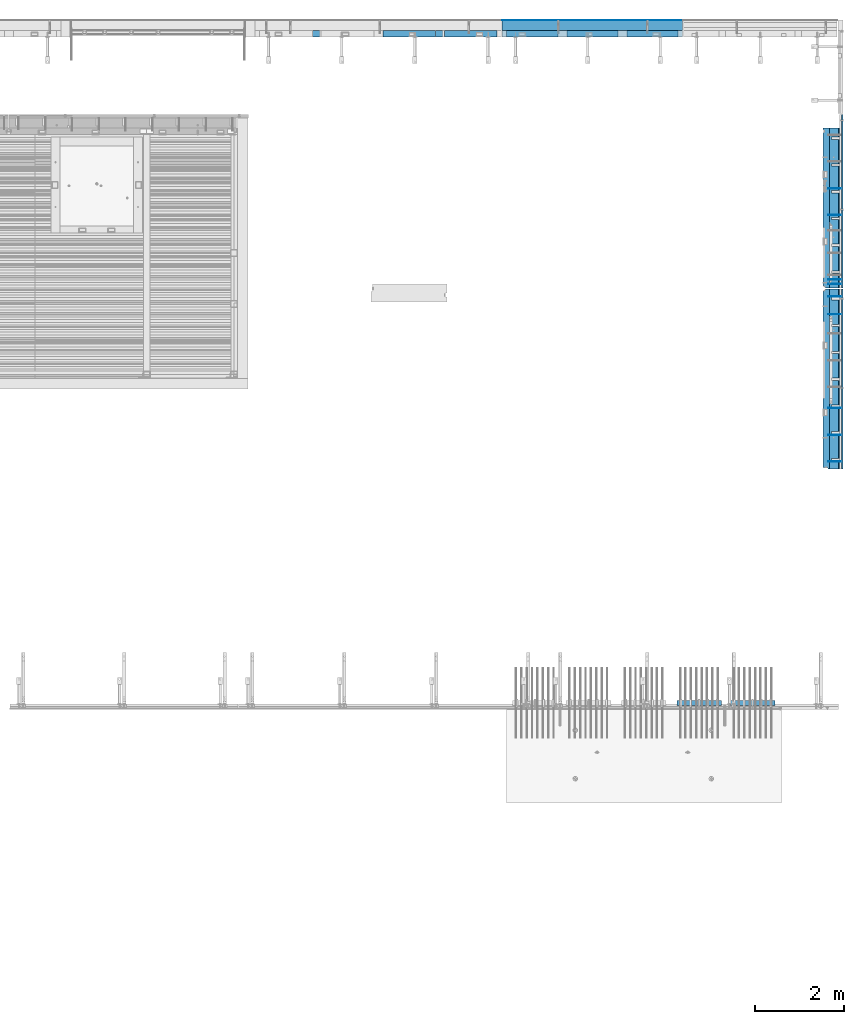
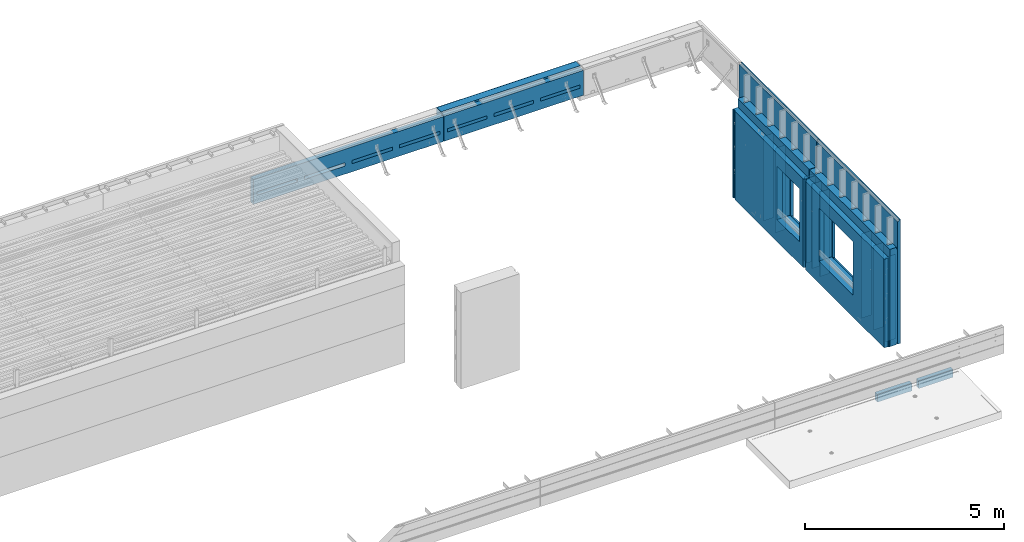
# One storey, part 81 of 153: 26 walls, 8 elements without a shape of their own.
"""IFC2X3 building model written with IfcOpenShell, lengths in millimetres."""

import ifcopenshell
import ifcopenshell.guid

model = None  # the IFC model being written
_history = None  # IfcOwnerHistory: only IFC2X3 demands one
_inside = {}  # id of a spatial element -> (the spatial element, [elements in it])
_under = {}  # id of a project, library or spatial element -> (it, [spatial elements below it])
_declared = {}  # id of a project -> (the project, [libraries it declares])
_typed = {}  # id of a type object -> (the type object, [elements of that type])
_made_of = {}  # id of a material, layer set ... -> (it, [elements and type objects made of it])


def new_model(schema):
    """Start an empty IFC model of exactly this schema.

    Asked for "IFC4X3", IfcOpenShell would pick the latest addendum, in which some entities
    have other attributes; the version numbers below select the first issue.
    IFC2X3 requires an IfcOwnerHistory on every rooted entity: one is made here for all.
    """
    global model, _history
    if schema == "IFC4X3":
        model = ifcopenshell.file(schema_version=(4, 3, 0, 0))
    else:
        model = ifcopenshell.file(schema=schema)
    _inside.clear()
    _under.clear()
    _declared.clear()
    _typed.clear()
    _made_of.clear()
    _history = None
    if model.schema == "IFC2X3":
        org = make("IfcOrganization", Name="unknown")
        user = make(
            "IfcPersonAndOrganization",
            ThePerson=make("IfcPerson", FamilyName="unknown"),
            TheOrganization=org,
        )
        app = make(
            "IfcApplication",
            ApplicationDeveloper=org,
            Version="unknown",
            ApplicationFullName="unknown",
            ApplicationIdentifier="unknown",
        )
        _history = make(
            "IfcOwnerHistory",
            OwningUser=user,
            OwningApplication=app,
            ChangeAction="ADDED",
            CreationDate=0,
        )
    return model


def make(cls, **values):
    """One entity of the class cls with the attributes given. An attribute that is None is left unset."""
    return model.create_entity(
        cls, **{name: value for name, value in values.items() if value is not None}
    )


def rooted(cls, **values):
    """An entity with a GlobalId (a new one), such as an element, a storey or a relation."""
    return make(cls, GlobalId=ifcopenshell.guid.new(), OwnerHistory=_history, **values)


def si_unit(unit_type, name, prefix=None):
    """IfcSIUnit, for example si_unit("LENGTHUNIT", "METRE", prefix="MILLI")."""
    return make("IfcSIUnit", UnitType=unit_type, Prefix=prefix, Name=name)


def assignment(units):
    """IfcUnitAssignment: the units of a project."""
    return None if units is None else make("IfcUnitAssignment", Units=units)


def point(xyz):
    """IfcCartesianPoint."""
    return None if xyz is None else make("IfcCartesianPoint", Coordinates=xyz)


def direction(xyz):
    """IfcDirection."""
    return None if xyz is None else make("IfcDirection", DirectionRatios=xyz)


def frame(location, z_axis=None, x_axis=None):
    """IfcAxis2Placement3D, a coordinate frame: its origin and axes. An axis left out is left unset."""
    return make(
        "IfcAxis2Placement3D",
        Location=point(location),
        Axis=direction(z_axis),
        RefDirection=direction(x_axis),
    )


def origin_with_axes():
    """The frame at (0, 0, 0) with the z axis (0, 0, 1) and the x axis (1, 0, 0) written out."""
    return frame((0.0, 0.0, 0.0), z_axis=(0.0, 0.0, 1.0), x_axis=(1.0, 0.0, 0.0))


def place(relative_to, where):
    """IfcLocalPlacement: puts the frame where relative to a parent placement (None: the world)."""
    return make(
        "IfcLocalPlacement", PlacementRelTo=relative_to, RelativePlacement=where
    )


def context(
    kind, dimensions, precision=None, world=None, true_north=None, identifier=None
):
    """IfcGeometricRepresentationContext, for example the 3D "Model" context."""
    return make(
        "IfcGeometricRepresentationContext",
        ContextIdentifier=identifier,
        ContextType=kind,
        CoordinateSpaceDimension=dimensions,
        Precision=precision,
        WorldCoordinateSystem=world,
        TrueNorth=true_north,
    )


def subcontext(parent, identifier, kind, view, scale=None):
    """IfcGeometricRepresentationSubContext, for example "Body" below "Model"."""
    return make(
        "IfcGeometricRepresentationSubContext",
        ContextIdentifier=identifier,
        ContextType=kind,
        ParentContext=parent,
        TargetScale=scale,
        TargetView=view,
    )


def project(units=None, contexts=None):
    """IfcProject with its units and contexts."""
    return rooted(
        "IfcProject",
        Name="project",
        RepresentationContexts=contexts,
        UnitsInContext=assignment(units),
    )


def spatial(cls, under=None, at=None, **own):
    """A site, building, storey or space (cls), placed at a placement, below another one or the project."""
    s = rooted(cls, ObjectPlacement=at, **own)
    if under is not None:
        _under.setdefault(under.id(), (under, []))[1].append(s)
    return s


def faces_of(points, faces, orient=None, outer=None):
    """IfcFace entities. A face is a list of loops; a loop is a list of indices into points, from 0.

    orient and outer hold one flag for each loop. By default every Orientation is true, the
    first loop of a face is its IfcFaceOuterBound and the others are IfcFaceBound.
    """
    made = []
    for i, loops in enumerate(faces):
        bounds = []
        for j, loop in enumerate(loops):
            is_outer = j == 0 if outer is None else outer[i][j]
            bounds.append(
                make(
                    "IfcFaceOuterBound" if is_outer else "IfcFaceBound",
                    Bound=make("IfcPolyLoop", Polygon=[points[k] for k in loop]),
                    Orientation=True if orient is None else orient[i][j],
                )
            )
        made.append(make("IfcFace", Bounds=bounds))
    return made


def faceted_brep(points, faces, orient=None, outer=None, voids=None):
    """IfcFacetedBrep: a solid bounded by flat faces; with voids (closed shells), ...WithVoids."""
    shared = [point(p) for p in points]
    hull = make("IfcClosedShell", CfsFaces=faces_of(shared, faces, orient, outer))
    if voids is None:
        return make("IfcFacetedBrep", Outer=hull)
    return make(
        "IfcFacetedBrepWithVoids",
        Outer=hull,
        Voids=[
            make(cls, CfsFaces=faces_of(shared, fs, o, b)) for cls, fs, o, b in voids
        ],
    )


def shape(context_of_items, identifier, shape_type, items):
    """IfcShapeRepresentation: the items that make up one representation, for example the "Body"."""
    return make(
        "IfcShapeRepresentation",
        ContextOfItems=context_of_items,
        RepresentationIdentifier=identifier,
        RepresentationType=shape_type,
        Items=items,
    )


def material(Name=None, Category=None):
    """IfcMaterial."""
    return make("IfcMaterial", Name=Name, Category=Category)


def made_of(thing, what):
    """Note that an element or type object is made of a material, layer set ...; save() writes the relation."""
    if what is not None:
        _made_of.setdefault(what.id(), (what, []))[1].append(thing)
    return thing


def type_object(cls, material=None, **own):
    """A type object (cls), such as IfcWallType, which elements share."""
    return made_of(rooted(cls, **own), material)


def element(
    cls,
    number,
    at=None,
    inside=None,
    cuts=None,
    type_object=None,
    material=None,
    context=None,
    identifier="Body",
    shape_type=None,
    held_by="IfcProductDefinitionShape",
    body=None,
    shapes=None,
    **own,
):
    """One element of the class cls, such as IfcWall. Its Tag is "e" and its number.

    at: its placement. inside: the storey or other place that contains it. cuts: it is an
    opening in that element (IfcRelVoidsElement). A single representation is given by context,
    identifier, shape_type and body (its items); several are given by shapes. held_by: the class
    of the entity that holds the representations. save() writes the other relations.
    """
    e = rooted(cls, Tag="e%d" % number, ObjectPlacement=at, **own)
    if body is not None:
        shapes = [shape(context, identifier, shape_type, body)]
    if shapes is not None:
        e.Representation = make(held_by, Representations=shapes)
    if inside is not None:
        _inside.setdefault(inside.id(), (inside, []))[1].append(e)
    if cuts is not None:
        rooted(
            "IfcRelVoidsElement", RelatingBuildingElement=cuts, RelatedOpeningElement=e
        )
    if type_object is not None:
        _typed.setdefault(type_object.id(), (type_object, []))[1].append(e)
    return made_of(e, material)


def aggregate(whole, parts):
    """IfcRelAggregates: a whole, such as a stair, and the parts it consists of."""
    return rooted("IfcRelAggregates", RelatingObject=whole, RelatedObjects=parts)


def save(model, path):
    """Write the relations noted so far, then the file.

    IfcRelAggregates (storeys below a building ...), IfcRelContainedInSpatialStructure (elements
    in a storey), IfcRelDefinesByType, IfcRelAssociatesMaterial and IfcRelDeclares: one each for
    every whole, place, type object, material and project.
    """
    for whole, parts in _under.values():
        aggregate(whole, parts)
    for where, things in _inside.values():
        rooted(
            "IfcRelContainedInSpatialStructure",
            RelatedElements=things,
            RelatingStructure=where,
        )
    for kind, things in _typed.values():
        rooted("IfcRelDefinesByType", RelatedObjects=things, RelatingType=kind)
    for what, things in _made_of.values():
        rooted("IfcRelAssociatesMaterial", RelatedObjects=things, RelatingMaterial=what)
    for by, libraries in _declared.values():
        rooted("IfcRelDeclares", RelatingContext=by, RelatedDefinitions=libraries)
    model.write(path)


model = new_model("IFC2X3")

# Units and contexts
model_context = context("Model", 3, precision=1e-05, world=origin_with_axes())
body_context = subcontext(model_context, "Body", "Model", "MODEL_VIEW")
ifc_project = project(units=[si_unit("LENGTHUNIT", "METRE", prefix="MILLI"), si_unit("AREAUNIT", "SQUARE_METRE"), si_unit("VOLUMEUNIT", "CUBIC_METRE"), si_unit("MASSUNIT", "GRAM", prefix="KILO"), si_unit("TIMEUNIT", "SECOND"), si_unit("PLANEANGLEUNIT", "RADIAN"), si_unit("SOLIDANGLEUNIT", "STERADIAN"), si_unit("THERMODYNAMICTEMPERATUREUNIT", "DEGREE_CELSIUS"), si_unit("LUMINOUSINTENSITYUNIT", "LUMEN")], contexts=[model_context])

# Site, building, storey
site_placement = place(None, origin_with_axes())
site = spatial("IfcSite", under=ifc_project, at=site_placement, CompositionType="ELEMENT")
building_placement = place(site_placement, origin_with_axes())
building = spatial("IfcBuilding", under=site, at=building_placement, CompositionType="ELEMENT")
storey_placement = place(building_placement, origin_with_axes())
storey = spatial("IfcBuildingStorey", under=building, at=storey_placement, Name="8", CompositionType="ELEMENT", Elevation=0.0)

# Assembly, walls
assembly_1_placement = place(storey_placement, origin_with_axes())
assembly_1 = element("IfcElementAssembly", 1, at=assembly_1_placement, inside=storey, AssemblyPlace="NOTDEFINED", PredefinedType="REINFORCEMENT_UNIT")
ifc_material_1 = material(Name="Undefined")
wall_type_1 = type_object("IfcWallType", PredefinedType="NOTDEFINED")
wall_1_placement = place(assembly_1_placement, frame((35030.0, 13100.0002861023, 101115.0), z_axis=(0.0, 0.0, 1.0), x_axis=(1.0, 0.0, 0.0)))
wall_1 = element("IfcWall", 2, at=wall_1_placement, type_object=wall_type_1, material=ifc_material_1, Name="(PD)", context=body_context, shape_type="Brep", body=[
    faceted_brep([(0.0, 5.0, -1300.0), (0.0, 5.0, 1300.0), (280.0, 5.0, 1300.0), (280.0, 5.0, -1300.0), (0.0, -5.0, 1300.0), (280.0, -5.0, 1300.0), (0.0, -5.0, -1300.0), (280.0, -5.0, -1300.0)], [[[0, 1, 2, 3]], [[1, 4, 5, 2]], [[4, 6, 7, 5]], [[6, 0, 3, 7]], [[5, 7, 3, 2]], [[6, 4, 1, 0]]]),
])
wall_2_placement = place(assembly_1_placement, frame((35030.0, 13700.0002861023, 101115.0), z_axis=(0.0, 0.0, 1.0), x_axis=(1.0, 0.0, 0.0)))
wall_2 = element("IfcWall", 3, at=wall_2_placement, type_object=wall_type_1, material=ifc_material_1, Name="(PD)", context=body_context, shape_type="Brep", body=[
    faceted_brep([(0.0, 5.0, -1300.0), (0.0, 5.0, 1300.0), (280.0, 5.0, 1300.0), (280.0, 5.0, -1300.0), (0.0, -5.0, 1300.0), (280.0, -5.0, 1300.0), (0.0, -5.0, -1300.0), (280.0, -5.0, -1300.0)], [[[0, 1, 2, 3]], [[1, 4, 5, 2]], [[4, 6, 7, 5]], [[6, 0, 3, 7]], [[5, 7, 3, 2]], [[6, 4, 1, 0]]]),
])
wall_3_placement = place(assembly_1_placement, frame((35030.0, 16804.6502861023, 101115.0), z_axis=(0.0, 0.0, 1.0), x_axis=(1.0, 0.0, 0.0)))
wall_3 = element("IfcWall", 4, at=wall_3_placement, type_object=wall_type_1, material=ifc_material_1, Name="(PD)", context=body_context, shape_type="Brep", body=[
    faceted_brep([(0.0, 5.0, -1300.0), (0.0, 5.0, 1300.0), (280.0, 5.0, 1300.0), (280.0, 5.0, -1300.0), (0.0, -5.0, 1300.0), (280.0, -5.0, 1300.0), (0.0, -5.0, -1300.0), (280.0, -5.0, -1300.0)], [[[0, 1, 2, 3]], [[1, 4, 5, 2]], [[4, 6, 7, 5]], [[6, 0, 3, 7]], [[5, 7, 3, 2]], [[6, 4, 1, 0]]]),
])
wall_4_placement = place(assembly_1_placement, frame((35030.0, 16404.6502861023, 101115.0), z_axis=(0.0, 0.0, 1.0), x_axis=(1.0, 0.0, 0.0)))
wall_4 = element("IfcWall", 5, at=wall_4_placement, type_object=wall_type_1, material=ifc_material_1, Name="(PD)", context=body_context, shape_type="Brep", body=[
    faceted_brep([(0.0, 5.0, -1300.0), (0.0, 5.0, 1300.0), (280.0, 5.0, 1300.0), (280.0, 5.0, -1300.0), (0.0, -5.0, 1300.0), (280.0, -5.0, 1300.0), (0.0, -5.0, -1300.0), (280.0, -5.0, -1300.0)], [[[0, 1, 2, 3]], [[1, 4, 5, 2]], [[4, 6, 7, 5]], [[6, 0, 3, 7]], [[5, 7, 3, 2]], [[6, 4, 1, 0]]]),
])

assembly_2_placement = place(storey_placement, origin_with_axes())
assembly_2 = element("IfcElementAssembly", 6, at=assembly_2_placement, inside=storey, AssemblyPlace="NOTDEFINED", PredefinedType="REINFORCEMENT_UNIT")
wall_5_placement = place(assembly_2_placement, frame((35030.0, 18625.0002441406, 101115.0), z_axis=(0.0, 0.0, 1.0), x_axis=(1.0, 0.0, 0.0)))
wall_5 = element("IfcWall", 7, at=wall_5_placement, type_object=wall_type_1, material=ifc_material_1, Name="(PD)", context=body_context, shape_type="Brep", body=[
    faceted_brep([(0.0, 5.0, -1300.0), (0.0, 5.0, 1300.0), (280.0, 5.0, 1300.0), (280.0, 5.0, -1300.0), (0.0, -5.0, 1300.0), (280.0, -5.0, 1300.0), (0.0, -5.0, -1300.0), (280.0, -5.0, -1300.0)], [[[0, 1, 2, 3]], [[1, 4, 5, 2]], [[4, 6, 7, 5]], [[6, 0, 3, 7]], [[5, 7, 3, 2]], [[6, 4, 1, 0]]]),
])
wall_6_placement = place(assembly_2_placement, frame((35030.0, 19225.0002441406, 101115.0), z_axis=(0.0, 0.0, 1.0), x_axis=(1.0, 0.0, 0.0)))
wall_6 = element("IfcWall", 8, at=wall_6_placement, type_object=wall_type_1, material=ifc_material_1, Name="(PD)", context=body_context, shape_type="Brep", body=[
    faceted_brep([(0.0, 5.0, -1300.0), (0.0, 5.0, 1300.0), (280.0, 5.0, 1300.0), (280.0, 5.0, -1300.0), (0.0, -5.0, 1300.0), (280.0, -5.0, 1300.0), (0.0, -5.0, -1300.0), (280.0, -5.0, -1300.0)], [[[0, 1, 2, 3]], [[1, 4, 5, 2]], [[4, 6, 7, 5]], [[6, 0, 3, 7]], [[5, 7, 3, 2]], [[6, 4, 1, 0]]]),
])
wall_7_placement = place(assembly_2_placement, frame((35030.0, 17180.0002441406, 101115.0), z_axis=(0.0, 0.0, 1.0), x_axis=(1.0, 0.0, 0.0)))
wall_7 = element("IfcWall", 9, at=wall_7_placement, type_object=wall_type_1, material=ifc_material_1, Name="(PD)", context=body_context, shape_type="Brep", body=[
    faceted_brep([(0.0, 5.0, -1300.0), (0.0, 5.0, 1300.0), (280.0, 5.0, 1300.0), (280.0, 5.0, -1300.0), (0.0, -5.0, 1300.0), (280.0, -5.0, 1300.0), (0.0, -5.0, -1300.0), (280.0, -5.0, -1300.0)], [[[0, 1, 2, 3]], [[1, 4, 5, 2]], [[4, 6, 7, 5]], [[6, 0, 3, 7]], [[5, 7, 3, 2]], [[6, 4, 1, 0]]]),
])
wall_8_placement = place(assembly_2_placement, frame((35030.0, 17080.0002441406, 101115.0), z_axis=(0.0, 0.0, 1.0), x_axis=(1.0, 0.0, 0.0)))
wall_8 = element("IfcWall", 10, at=wall_8_placement, type_object=wall_type_1, material=ifc_material_1, Name="(PD)", context=body_context, shape_type="Brep", body=[
    faceted_brep([(0.0, 5.0, -1300.0), (0.0, 5.0, 1300.0), (280.0, 5.0, 1300.0), (280.0, 5.0, -1300.0), (0.0, -5.0, 1300.0), (280.0, -5.0, 1300.0), (0.0, -5.0, -1300.0), (280.0, -5.0, -1300.0)], [[[0, 1, 2, 3]], [[1, 4, 5, 2]], [[4, 6, 7, 5]], [[6, 0, 3, 7]], [[5, 7, 3, 2]], [[6, 4, 1, 0]]]),
])

# Wall
wall_9_placement = place(assembly_1_placement, frame((35030.0, 14300.0002861023, 101115.0), z_axis=(0.0, 0.0, 1.0), x_axis=(1.0, 0.0, 0.0)))
wall_9 = element("IfcWall", 11, at=wall_9_placement, type_object=wall_type_1, material=ifc_material_1, Name="(PD)", context=body_context, shape_type="Brep", body=[
    faceted_brep([(0.0, 5.0, -1300.0), (0.0, 5.0, 1300.0), (280.0, 5.0, 1300.0), (280.0, 5.0, -1300.0), (0.0, -5.0, 1300.0), (280.0, -5.0, 1300.0), (0.0, -5.0, -1300.0), (280.0, -5.0, -1300.0)], [[[0, 1, 2, 3]], [[1, 4, 5, 2]], [[4, 6, 7, 5]], [[6, 0, 3, 7]], [[5, 7, 3, 2]], [[6, 4, 1, 0]]]),
])

# Assemblies, walls
assembly_3_placement = place(storey_placement, origin_with_axes())
assembly_3 = element("IfcElementAssembly", 12, at=assembly_3_placement, inside=storey, AssemblyPlace="NOTDEFINED", PredefinedType="REINFORCEMENT_UNIT")
assembly_4_placement = place(assembly_3_placement, origin_with_axes())
assembly_4 = element("IfcElementAssembly", 13, at=assembly_4_placement, Name="Steel Assembly", AssemblyPlace="NOTDEFINED", PredefinedType="NOTDEFINED")
ifc_material_2 = material()
wall_type_2 = type_object("IfcWallType", PredefinedType="NOTDEFINED")
wall_10_placement = place(assembly_4_placement, frame((27719.9999060453, 22880.0000027105, 103162.5), z_axis=(0.0, 0.0, 1.0), x_axis=(1.0, 0.0, 0.0)))
wall_10 = element("IfcWall", 14, at=wall_10_placement, type_object=wall_type_2, material=ifc_material_2, context=body_context, shape_type="Brep", body=[
    faceted_brep([(0.0, 110.0, -407.5), (0.0, 110.0, 407.5), (4044.9964105508, 110.0, 407.5), (4044.9964105508, 110.0, -407.5), (0.0, -110.0, 407.5), (4044.9964105508, -109.999999999996, 407.5), (0.0, -110.0, -407.5), (4044.9964105508, -109.999999999996, -407.5)], [[[0, 1, 2, 3]], [[1, 4, 5, 2]], [[4, 6, 7, 5]], [[6, 0, 3, 7]], [[5, 7, 3, 2]], [[6, 4, 1, 0]]]),
])
aggregate(assembly_4, [wall_10])
ifc_material_3 = material()
wall_type_3 = type_object("IfcWallType", PredefinedType="NOTDEFINED")
wall_11_placement = place(assembly_3_placement, frame((27719.9998642852, 22995.0000027105, 103162.5), z_axis=(0.0, 0.0, 1.0), x_axis=(1.0, 0.0, 0.0)))
wall_11 = element("IfcWall", 15, at=wall_11_placement, type_object=wall_type_3, material=ifc_material_3, context=body_context, shape_type="Brep", body=[
    faceted_brep([(0.0, 5.0, -407.5), (0.0, 5.0, 407.5), (4044.99641541972, 4.99999999999636, 407.5), (4044.99641541972, 4.99999999999636, -407.5), (0.0, -5.0, 407.5), (4044.99641541972, -5.00000000000364, 407.5), (0.0, -5.0, -407.5), (4044.99641541972, -5.00000000000364, -407.5)], [[[0, 1, 2, 3]], [[1, 4, 5, 2]], [[4, 6, 7, 5]], [[6, 0, 3, 7]], [[5, 7, 3, 2]], [[6, 4, 1, 0]]]),
])
ifc_material_4 = material(Name="EPS")
wall_type_4 = type_object("IfcWallType", PredefinedType="NOTDEFINED")
wall_12_placement = place(assembly_3_placement, frame((30520.0, 22695.0, 103055.0), z_axis=(0.0, 1.0, 0.0), x_axis=(1.0, 0.0, 0.0)))
wall_12 = element("IfcWall", 16, at=wall_12_placement, type_object=wall_type_4, material=ifc_material_4, context=body_context, shape_type="Brep", body=[
    faceted_brep([(0.0, 50.0, -75.0), (0.0, 50.0, 75.0), (1145.0, 50.0, 75.0), (1145.0, 50.0, -75.0), (0.0, -50.0, 75.0), (1145.0, -50.0, 75.0), (0.0, -50.0, -75.0), (1145.0, -50.0, -75.0)], [[[0, 1, 2, 3]], [[1, 4, 5, 2]], [[4, 6, 7, 5]], [[6, 0, 3, 7]], [[5, 7, 3, 2]], [[6, 4, 1, 0]]]),
])
wall_13_placement = place(assembly_3_placement, frame((29170.0, 22695.0, 103055.0), z_axis=(0.0, 1.0, 0.0), x_axis=(1.0, 0.0, 0.0)))
wall_13 = element("IfcWall", 17, at=wall_13_placement, type_object=wall_type_4, material=ifc_material_4, context=body_context, shape_type="Brep", body=[
    faceted_brep([(0.0, 50.0, -75.0), (0.0, 50.0, 75.0), (1150.0, 50.0, 75.0), (1150.0, 50.0, -75.0), (0.0, -50.0, 75.0), (1150.0, -50.0, 75.0), (0.0, -50.0, -75.0), (1150.0, -50.0, -75.0)], [[[0, 1, 2, 3]], [[1, 4, 5, 2]], [[4, 6, 7, 5]], [[6, 0, 3, 7]], [[5, 7, 3, 2]], [[6, 4, 1, 0]]]),
])
wall_14_placement = place(assembly_3_placement, frame((27820.0, 22695.0, 103055.0), z_axis=(0.0, 1.0, 0.0), x_axis=(1.0, 0.0, 0.0)))
wall_14 = element("IfcWall", 18, at=wall_14_placement, type_object=wall_type_4, material=ifc_material_4, context=body_context, shape_type="Brep", body=[
    faceted_brep([(0.0, 50.0, -75.0), (0.0, 50.0, 75.0), (1150.0, 50.0, 75.0), (1150.0, 50.0, -75.0), (0.0, -50.0, 75.0), (1150.0, -50.0, 75.0), (0.0, -50.0, -75.0), (1150.0, -50.0, -75.0)], [[[0, 1, 2, 3]], [[1, 4, 5, 2]], [[4, 6, 7, 5]], [[6, 0, 3, 7]], [[5, 7, 3, 2]], [[6, 4, 1, 0]]]),
])

# Assembly, walls
assembly_5_placement = place(storey_placement, origin_with_axes())
assembly_5 = element("IfcElementAssembly", 19, at=assembly_5_placement, inside=storey, AssemblyPlace="NOTDEFINED", PredefinedType="REINFORCEMENT_UNIT")
wall_15_placement = place(assembly_5_placement, frame((26425.0, 22695.0, 103055.0), z_axis=(0.0, 1.0, 0.0), x_axis=(1.0, 0.0, 0.0)))
wall_15 = element("IfcWall", 20, at=wall_15_placement, type_object=wall_type_4, material=ifc_material_4, context=body_context, shape_type="Brep", body=[
    faceted_brep([(0.0, 50.0, -75.0), (0.0, 50.0, 75.0), (1180.0, 50.0, 75.0), (1180.0, 50.0, -75.0), (0.0, -50.0, 75.0), (1180.0, -50.0, 75.0), (0.0, -50.0, -75.0), (1180.0, -50.0, -75.0)], [[[0, 1, 2, 3]], [[1, 4, 5, 2]], [[4, 6, 7, 5]], [[6, 0, 3, 7]], [[5, 7, 3, 2]], [[6, 4, 1, 0]]]),
])
wall_16_placement = place(assembly_5_placement, frame((25045.0, 22695.0, 103055.0), z_axis=(0.0, 1.0, 0.0), x_axis=(1.0, 0.0, 0.0)))
wall_16 = element("IfcWall", 21, at=wall_16_placement, type_object=wall_type_4, material=ifc_material_4, context=body_context, shape_type="Brep", body=[
    faceted_brep([(0.0, 50.0, -75.0), (0.0, 50.0, 75.0), (1180.0, 50.0, 75.0), (1180.0, 50.0, -75.0), (0.0, -50.0, 75.0), (1180.0, -50.0, 75.0), (0.0, -50.0, -75.0), (1180.0, -50.0, -75.0)], [[[0, 1, 2, 3]], [[1, 4, 5, 2]], [[4, 6, 7, 5]], [[6, 0, 3, 7]], [[5, 7, 3, 2]], [[6, 4, 1, 0]]]),
])

# Assemblies, walls
assembly_6_placement = place(storey_placement, origin_with_axes())
assembly_6 = element("IfcElementAssembly", 22, at=assembly_6_placement, inside=storey, AssemblyPlace="NOTDEFINED", PredefinedType="REINFORCEMENT_UNIT")
assembly_7_placement = place(assembly_6_placement, origin_with_axes())
assembly_7 = element("IfcElementAssembly", 23, at=assembly_7_placement, Name="Steel Assembly", AssemblyPlace="NOTDEFINED", PredefinedType="NOTDEFINED")
ifc_material_5 = material()
wall_type_5 = type_object("IfcWallType", PredefinedType="NOTDEFINED")
wall_17_placement = place(assembly_7_placement, frame((32834.9998568133, 7690.00021946163, 102590.0), z_axis=(0.0, 0.0, 1.0), x_axis=(1.0, 0.0, 0.0)))
wall_17 = element("IfcWall", 24, at=wall_17_placement, type_object=wall_type_5, material=ifc_material_5, context=body_context, shape_type="Brep", body=[
    faceted_brep([(0.0, 60.0, -120.0), (0.0, 60.0, 120.0), (1000.0, 60.0, 120.0), (1000.0, 60.0, -120.0), (0.0, -60.0, 120.0), (1000.0, -60.0, 120.0), (0.0, -60.0, -120.0), (1000.0, -60.0, -120.0)], [[[0, 1, 2, 3]], [[1, 4, 5, 2]], [[4, 6, 7, 5]], [[6, 0, 3, 7]], [[5, 7, 3, 2]], [[6, 4, 1, 0]]]),
])
aggregate(assembly_7, [wall_17])
assembly_8_placement = place(assembly_6_placement, origin_with_axes())
assembly_8 = element("IfcElementAssembly", 25, at=assembly_8_placement, Name="Steel Assembly", AssemblyPlace="NOTDEFINED", PredefinedType="NOTDEFINED")
aggregate(assembly_6, [assembly_7, assembly_8])
wall_18_placement = place(assembly_8_placement, frame((31634.9998568133, 7690.00021946163, 102590.0), z_axis=(0.0, 0.0, 1.0), x_axis=(1.0, 0.0, 0.0)))
wall_18 = element("IfcWall", 26, at=wall_18_placement, type_object=wall_type_5, material=ifc_material_5, context=body_context, shape_type="Brep", body=[
    faceted_brep([(0.0, 60.0, -120.0), (0.0, 60.0, 120.0), (1000.0, 60.0, 120.0), (1000.0, 60.0, -120.0), (0.0, -60.0, 120.0), (1000.0, -60.0, 120.0), (0.0, -60.0, -120.0), (1000.0, -60.0, -120.0)], [[[0, 1, 2, 3]], [[1, 4, 5, 2]], [[4, 6, 7, 5]], [[6, 0, 3, 7]], [[5, 7, 3, 2]], [[6, 4, 1, 0]]]),
])
aggregate(assembly_8, [wall_18])

# Wall
ifc_material_6 = material(Name="COS5gt")
wall_type_6 = type_object("IfcWallType", PredefinedType="NOTDEFINED")
wall_19_placement = place(assembly_1_placement, frame((35170.0, 16980.0002861023, 101247.5), z_axis=(0.0, 0.0, 1.0), x_axis=(0.0, -1.0, 0.0)))
wall_19 = element("IfcWall", 27, at=wall_19_placement, type_object=wall_type_6, material=ifc_material_6, context=body_context, shape_type="Brep", body=[
    faceted_brep([(3855.00004196167, -65.0, 1492.5), (3855.00004196167, -65.0, 622.5), (3805.00004196167, -65.0, 622.5), (3805.00004196167, -65.0, 1492.5), (3855.00004196167, 110.0, 1442.5), (3855.00004196167, 110.0, 622.5), (3855.00004196167, 90.0, 1492.5), (3855.00004196167, 90.0, 1442.5), (3805.00004196167, 110.0, 622.5), (3805.00004196167, 110.0, 1442.5), (3805.00004196167, 90.0, 1442.5), (3805.00004196167, 90.0, 1492.5), (2655.00004196167, 110.0, 1442.5), (2655.00004196167, 90.0, 1442.5), (3205.00004196167, 90.0, 1442.5), (3205.00004196167, 110.0, 1442.5), (2055.00004196167, 110.0, 1442.5), (2055.00004196167, 90.0, 1442.5), (2605.00004196167, 90.0, 1442.5), (2605.00004196167, 110.0, 1442.5), (1455.00004196167, 110.0, 1442.5), (1455.00004196167, 90.0, 1442.5), (2005.00004196167, 90.0, 1442.5), (2005.00004196167, 110.0, 1442.5), (855.00004196167, 110.0, 1442.5), (855.00004196167, 90.0, 1442.5), (1405.00004196167, 90.0, 1442.5), (1405.00004196167, 110.0, 1442.5), (255.0, 110.0, 1442.5), (255.0, 90.0, 1442.5), (805.00004196167, 90.0, 1442.5), (805.00004196167, 110.0, 1442.5), (1409.0, 90.0, -1492.5), (1409.0, 90.0, -1442.5), (4045.0, 90.0, -1442.5), (4045.0, 90.0, -1492.5), (4045.0, -110.0, -1492.5), (5.0, -110.0, -1492.5), (5.0, 110.0, -1492.5), (1409.0, 110.0, -1492.5), (1409.0, 110.0, -1442.5), (4045.0, 110.0, -1442.5), (4045.0, 110.0, 1442.5), (4045.0, 90.0, 1442.5), (4045.0, 90.0, 1492.5), (4045.0, -110.0, 1492.5), (2454.99993815724, 110.0, -802.5), (2454.99993815724, 110.0, -807.5), (2460.94588410319, -110.0, -813.445945945947), (2460.94588410319, -110.0, 813.445945945947), (2454.99993815724, 110.0, 807.5), (2424.99993815724, 110.0, -807.5), (774.99993815724, 110.0, -807.5), (744.99993815724, 110.0, -807.5), (739.053992211293, -110.0, -813.445945945947), (744.99993815724, 110.0, -802.5), (744.99993815724, 110.0, 807.5), (739.053992211293, -110.0, 813.445945945947), (5.0, -110.0, 1492.5), (5.00004196166992, 110.0, 1442.5), (5.00004196166992, 90.0, 1442.5), (205.00004196167, 90.0, 1442.5), (205.00004196167, 110.0, 1442.5), (5.00004196166992, 90.0, 1492.5), (205.00004196167, 90.0, 1492.5), (205.00004196167, 110.0, 622.5), (205.00004196167, -65.0, 622.5), (255.00004196167, -65.0, 622.5), (255.00004196167, 110.0, 622.5), (205.00004196167, -65.0, 1492.5), (255.00004196167, -65.0, 1492.5), (255.0, 90.0, 1492.5), (805.00004196167, 90.0, 1492.5), (805.00004196167, 110.0, 817.5), (805.00004196167, -65.0, 817.5), (855.00004196167, -65.0, 817.5), (855.00004196167, 110.0, 817.5), (805.00004196167, -65.0, 1492.5), (855.00004196167, -65.0, 1492.5), (855.00004196167, 90.0, 1492.5), (1405.00004196167, 90.0, 1492.5), (1405.00004196167, 110.0, 817.5), (1405.00004196167, -65.0, 817.5), (1455.00004196167, -65.0, 817.5), (1455.00004196167, 110.0, 817.5), (1405.00004196167, -65.0, 1492.5), (1455.00004196167, -65.0, 1492.5), (1455.00004196167, 90.0, 1492.5), (2005.00004196167, 90.0, 1492.5), (2005.00004196167, 110.0, 817.5), (2005.00004196167, -65.0, 817.5), (2055.00004196167, -65.0, 817.5), (2055.00004196167, 110.0, 817.5), (2005.00004196167, -65.0, 1492.5), (2055.00004196167, -65.0, 1492.5), (2055.00004196167, 90.0, 1492.5), (2605.00004196167, 90.0, 1492.5), (2605.00004196167, 110.0, 622.5), (2605.00004196167, -65.0, 622.5), (2655.00004196167, -65.0, 622.5), (2655.00004196167, 110.0, 622.5), (2605.00004196167, -65.0, 1492.5), (2655.00004196167, -65.0, 1492.5), (2655.00004196167, 90.0, 1492.5), (3205.00004196167, 90.0, 1492.5), (3205.00004196167, 110.0, 622.5), (3205.00004196167, -65.0, 622.5), (3255.00004196167, -65.0, 622.5), (3255.00004196167, 110.0, 622.5), (3205.00004196167, -65.0, 1492.5), (3255.00004196167, -65.0, 1492.5), (3255.00004196167, 110.0, 1442.5), (3255.00004196167, 90.0, 1492.5), (3255.00004196167, 90.0, 1442.5)], [[[0, 1, 2, 3]], [[4, 5, 1, 0, 6, 7]], [[8, 2, 1, 5]], [[9, 10, 11, 3, 2, 8]], [[12, 13, 14, 15]], [[16, 17, 18, 19]], [[20, 21, 22, 23]], [[24, 25, 26, 27]], [[28, 29, 30, 31]], [[32, 33, 34, 35]], [[35, 36, 37, 38, 39, 32]], [[40, 33, 32, 39]], [[41, 34, 33, 40]], [[42, 43, 44, 45, 36, 35, 34, 41]], [[46, 47, 48, 49, 50]], [[51, 52, 53, 54, 48, 47]], [[55, 56, 57, 54, 53]], [[50, 49, 57, 56]], [[58, 37, 36, 45], [48, 54, 57, 49]], [[59, 60, 61, 62]], [[38, 37, 58, 63, 60, 59]], [[60, 63, 64, 61]], [[65, 66, 67, 68]], [[62, 61, 64, 69, 66, 65]], [[70, 67, 66, 69]], [[28, 68, 67, 70, 71, 29]], [[29, 71, 72, 30]], [[73, 74, 75, 76]], [[31, 30, 72, 77, 74, 73]], [[78, 75, 74, 77]], [[24, 76, 75, 78, 79, 25]], [[25, 79, 80, 26]], [[81, 82, 83, 84]], [[27, 26, 80, 85, 82, 81]], [[86, 83, 82, 85]], [[20, 84, 83, 86, 87, 21]], [[21, 87, 88, 22]], [[89, 90, 91, 92]], [[23, 22, 88, 93, 90, 89]], [[94, 91, 90, 93]], [[16, 92, 91, 94, 95, 17]], [[17, 95, 96, 18]], [[97, 98, 99, 100]], [[19, 18, 96, 101, 98, 97]], [[102, 99, 98, 101]], [[12, 100, 99, 102, 103, 13]], [[13, 103, 104, 14]], [[105, 106, 107, 108]], [[15, 14, 104, 109, 106, 105]], [[110, 107, 106, 109]], [[111, 108, 107, 110, 112, 113]], [[5, 4, 42, 41, 40, 39, 38, 59, 62, 65, 68, 28, 31, 73, 76, 24, 27, 81, 84, 20, 23, 89, 92, 16, 19, 97, 100, 12, 15, 105, 108, 111, 9, 8], [53, 52, 51, 47, 46, 50, 56, 55]], [[43, 42, 4, 7]], [[44, 43, 7, 6]], [[112, 110, 109, 104, 103, 102, 101, 96, 95, 94, 93, 88, 87, 86, 85, 80, 79, 78, 77, 72, 71, 70, 69, 64, 63, 58, 45, 44, 6, 0, 3, 11]], [[113, 112, 11, 10]], [[111, 113, 10, 9]]]),
])

wall_20_placement = place(assembly_2_placement, frame((35170.0, 20575.0002441406, 101247.5), z_axis=(0.0, 0.0, 1.0), x_axis=(0.0, -1.0, 0.0)))
wall_20 = element("IfcWall", 28, at=wall_20_placement, type_object=wall_type_6, material=ifc_material_6, context=body_context, shape_type="Brep", body=[
    faceted_brep([(250.0, -65.0, 1492.5), (250.0, -65.0, 622.5), (200.0, -65.0, 622.5), (200.0, -65.0, 1492.5), (250.0, 110.0, 1442.5), (250.0, 110.0, 622.5), (250.0, 90.0, 1492.5), (250.0, 90.0, 1442.5), (200.0, 110.0, 622.5), (200.0, 110.0, 1442.5), (200.0, 90.0, 1442.5), (200.0, 90.0, 1492.5), (3585.0, 90.0, 1442.5), (3585.0, 110.0, 1442.5), (3250.0, 110.0, 1442.5), (3250.0, 90.0, 1442.5), (3200.0, 90.0, 1442.5), (3200.0, 110.0, 1442.5), (2650.0, 110.0, 1442.5), (2650.0, 90.0, 1442.5), (2600.0, 90.0, 1442.5), (2600.0, 110.0, 1442.5), (2050.0, 110.0, 1442.5), (2050.0, 90.0, 1442.5), (2000.0, 90.0, 1442.5), (2000.0, 110.0, 1442.5), (1450.0, 110.0, 1442.5), (1450.0, 90.0, 1442.5), (1400.0, 90.0, 1442.5), (1400.0, 110.0, 1442.5), (850.0, 110.0, 1442.5), (850.0, 90.0, 1442.5), (800.0, 110.0, 622.5), (800.0, -65.0, 622.5), (850.0, -65.0, 622.5), (850.0, 110.0, 622.5), (800.0, 110.0, 1442.5), (800.0, 90.0, 1442.5), (800.0, 90.0, 1492.5), (800.0, -65.0, 1492.5), (850.0, -65.0, 1492.5), (850.0, 90.0, 1492.5), (1400.0, 90.0, 1492.5), (1400.0, 110.0, 622.5), (1400.0, -65.0, 622.5), (1450.0, -65.0, 622.5), (1450.0, 110.0, 622.5), (1400.0, -65.0, 1492.5), (1450.0, -65.0, 1492.5), (1450.0, 90.0, 1492.5), (2000.0, 90.0, 1492.5), (2000.0, 110.0, 622.5), (2000.0, -65.0, 622.5), (2050.0, -65.0, 622.5), (2050.0, 110.0, 622.5), (2000.0, -65.0, 1492.5), (2050.0, -65.0, 1492.5), (2050.0, 90.0, 1492.5), (2600.0, 90.0, 1492.5), (2600.0, 110.0, 817.5), (2600.0, -65.0, 817.5), (2650.0, -65.0, 817.5), (2650.0, 110.0, 817.5), (2600.0, -65.0, 1492.5), (2650.0, -65.0, 1492.5), (2650.0, 90.0, 1492.5), (3200.0, 90.0, 1492.5), (3200.0, 110.0, 817.5), (3200.0, -65.0, 817.5), (3250.0, -65.0, 817.5), (3250.0, 110.0, 817.5), (3200.0, -65.0, 1492.5), (3250.0, -65.0, 1492.5), (3250.0, 90.0, 1492.5), (3585.0, 90.0, 1492.5), (3585.0, -110.0, 1492.5), (3585.0, -110.0, -1492.5), (3585.0, 90.0, -1492.5), (3585.0, 90.0, -1442.5), (3585.0, 110.0, -1442.5), (3349.99987343476, 110.0, -802.5), (3349.99987343476, 110.0, -807.5), (3355.94581938071, -110.0, -813.445945945947), (3355.94581938071, -110.0, 813.445945945947), (3349.99987343476, 110.0, 807.5), (3319.99987343476, 110.0, -807.5), (2269.99987343476, 110.0, -807.5), (2239.99987343476, 110.0, -807.5), (2234.05392748882, -110.0, -813.445945945947), (2239.99987343476, 110.0, -802.5), (2239.99987343476, 110.0, 807.5), (2234.05392748882, -110.0, 813.445945945947), (0.0, -110.0, 1492.5), (0.0, -110.0, -1492.5), (0.0, 90.0, -1492.5), (0.0, 90.0, -1442.5), (0.0, 110.0, -1442.5), (0.0, 90.0, 1492.5), (0.0, 90.0, 1442.5), (0.0, 110.0, 1442.5)], [[[0, 1, 2, 3]], [[4, 5, 1, 0, 6, 7]], [[8, 2, 1, 5]], [[9, 10, 11, 3, 2, 8]], [[12, 13, 14, 15]], [[16, 17, 18, 19]], [[20, 21, 22, 23]], [[24, 25, 26, 27]], [[28, 29, 30, 31]], [[32, 33, 34, 35]], [[36, 37, 38, 39, 33, 32]], [[40, 34, 33, 39]], [[30, 35, 34, 40, 41, 31]], [[42, 28, 31, 41]], [[43, 44, 45, 46]], [[29, 28, 42, 47, 44, 43]], [[48, 45, 44, 47]], [[26, 46, 45, 48, 49, 27]], [[50, 24, 27, 49]], [[51, 52, 53, 54]], [[25, 24, 50, 55, 52, 51]], [[56, 53, 52, 55]], [[22, 54, 53, 56, 57, 23]], [[58, 20, 23, 57]], [[59, 60, 61, 62]], [[21, 20, 58, 63, 60, 59]], [[64, 61, 60, 63]], [[18, 62, 61, 64, 65, 19]], [[66, 16, 19, 65]], [[67, 68, 69, 70]], [[17, 16, 66, 71, 68, 67]], [[72, 69, 68, 71]], [[14, 70, 69, 72, 73, 15]], [[74, 12, 15, 73]], [[13, 12, 74, 75, 76, 77, 78, 79]], [[80, 81, 82, 83, 84]], [[85, 86, 87, 88, 82, 81]], [[89, 90, 91, 88, 87]], [[84, 83, 91, 90]], [[92, 93, 76, 75], [82, 88, 91, 83]], [[76, 93, 94, 77]], [[95, 78, 77, 94]], [[96, 79, 78, 95]], [[94, 93, 92, 97, 98, 99, 96, 95]], [[5, 4, 36, 32, 35, 30, 29, 43, 46, 26, 25, 51, 54, 22, 21, 59, 62, 18, 17, 67, 70, 14, 13, 79, 96, 99, 9, 8], [87, 86, 85, 81, 80, 84, 90, 89]], [[37, 36, 4, 7]], [[38, 37, 7, 6]], [[97, 92, 75, 74, 73, 72, 71, 66, 65, 64, 63, 58, 57, 56, 55, 50, 49, 48, 47, 42, 41, 40, 39, 38, 6, 0, 3, 11]], [[98, 97, 11, 10]], [[99, 98, 10, 9]]]),
])

ifc_material_7 = material(Name="CONCRETE/C25/30")
wall_type_7 = type_object("IfcWallType", PredefinedType="NOTDEFINED")
wall_21_placement = place(assembly_1_placement, frame((34985.0, 16980.0002861023, 101112.5), z_axis=(0.0, 0.0, 1.0), x_axis=(0.0, -1.0, 0.0)))
wall_21 = element("IfcWall", 29, at=wall_21_placement, type_object=wall_type_7, material=ifc_material_7, context=body_context, shape_type="Brep", body=[
    faceted_brep([(5.0, 75.0, -1357.5), (5.0, 75.0, 1357.5), (4045.0, 75.0, 1357.5), (4045.0, 75.0, -1357.5), (2460.94588410319, 75.0, -678.445945945947), (2460.94588410319, 75.0, 948.445945945947), (739.053992211293, 75.0, 948.445945945947), (739.053992211293, 75.0, -678.445945945947), (5.0, -15.0000022791291, -1357.5), (5.0, -15.0000022791291, 1357.5), (65.0, -75.0, 1357.5), (65.0, -75.0, -1357.5), (4015.0, -75.0, 1357.5), (4015.0, 32.0, 1357.5), (4045.0, 45.0, 1357.5), (4045.0, 45.0, -1357.5), (4015.0, -75.0, -1357.5), (4015.0, 32.0, -1357.5), (2464.99993815724, -75.0, -682.5), (734.99993815724, -75.0, -682.5), (734.99993815724, -75.0, 952.5), (2464.99993815724, -75.0, 952.5)], [[[0, 1, 2, 3], [4, 5, 6, 7]], [[1, 0, 8, 9]], [[10, 9, 8, 11]], [[2, 1, 9, 10, 12, 13, 14]], [[3, 2, 14, 15]], [[16, 11, 8, 0, 3, 15, 17]], [[14, 13, 17, 15]], [[12, 16, 17, 13]], [[10, 11, 16, 12], [18, 19, 20, 21]], [[6, 20, 19, 7]], [[5, 21, 20, 6]], [[4, 18, 21, 5]], [[7, 19, 18, 4]]]),
])

wall_22_placement = place(assembly_2_placement, frame((34985.0, 20575.0002441406, 101112.5), z_axis=(0.0, 0.0, 1.0), x_axis=(0.0, -1.0, 0.0)))
wall_22 = element("IfcWall", 30, at=wall_22_placement, type_object=wall_type_7, material=ifc_material_7, context=body_context, shape_type="Brep", body=[
    faceted_brep([(0.0, 75.0, -1357.5), (0.0, 75.0, 1357.5), (3585.0, 75.0, 1357.5), (3585.0, 75.0, -1357.5), (3355.94581938071, 75.0, -678.445945945947), (3355.94581938071, 75.0, 948.445945945947), (2234.05392748882, 75.0, 948.445945945947), (2234.05392748882, 75.0, -678.445945945947), (0.0, -75.0, -1357.5), (0.0, -75.0, 1357.5), (30.0050569130617, -75.0, -1357.5), (30.0050569130617, -75.0, 1357.5), (43.0050569130617, -55.0, -1357.5), (43.0050569130617, -55.0, 1357.5), (97.0050569130617, -55.0, -1357.5), (97.0050569130617, -55.0, 1357.5), (110.005056913062, -75.0, -1357.5), (110.005056913062, -75.0, 1357.5), (3525.0, -75.0, 1357.5), (3585.0, -15.0, 1357.5), (3585.0, -15.0, -1357.5), (3525.0, -75.0, -1357.5), (3359.99987343476, -75.0, -682.5), (2229.99987343476, -75.0, -682.5), (2229.99987343476, -75.0, 952.5), (3359.99987343476, -75.0, 952.5)], [[[0, 1, 2, 3], [4, 5, 6, 7]], [[8, 9, 1, 0]], [[9, 8, 10, 11]], [[11, 10, 12, 13]], [[13, 12, 14, 15]], [[15, 14, 16, 17]], [[2, 1, 9, 11, 13, 15, 17, 18, 19]], [[3, 2, 19, 20]], [[16, 14, 12, 10, 8, 0, 3, 20, 21]], [[19, 18, 21, 20]], [[17, 16, 21, 18], [22, 23, 24, 25]], [[6, 24, 23, 7]], [[5, 25, 24, 6]], [[4, 22, 25, 5]], [[7, 23, 22, 4]]]),
])

ifc_material_8 = material(Name="CONCRETE/C30/37")
wall_type_8 = type_object("IfcWallType", PredefinedType="NOTDEFINED")
wall_23_placement = place(assembly_1_placement, frame((35322.5, 16980.0002861023, 101662.5), z_axis=(0.0, 0.0, 1.0), x_axis=(0.0, -1.0, 0.0)))
wall_23 = element("IfcWall", 31, at=wall_23_placement, type_object=wall_type_8, material=ifc_material_8, context=body_context, shape_type="Brep", body=[
    faceted_brep([(5.00004196166992, -42.5, 1857.5), (4045.0, -42.5, 1857.5), (4045.0, 7.5, 1857.5), (5.0000419616772, 7.5, 1857.5), (5.0000419616772, 7.5, 1907.5), (4045.0, 7.5, 1907.5), (5.00004196166992, -42.5, -1907.5), (5.00004196166992, 42.5, -1907.5), (4045.0, 42.5, -1907.5), (4045.0, -42.5, -1907.5), (4045.0, 42.5, 1907.5), (5.00004196166992, 42.5, 1907.5), (2434.99993815724, 42.5, -1272.5), (2434.99993815724, 42.5, 367.5), (2424.99993815724, 42.5, 367.5), (774.99993815724, 42.5, 367.5), (764.99993815724, 42.5, 367.5), (764.99993815724, 42.5, -1272.5), (2424.99993815724, -42.5, -1222.5), (2424.99993815724, -42.5, 367.5), (2424.99993815724, -42.5, 372.5), (774.99993815724, -42.5, -1222.5), (774.99993815724, -42.5, 372.5), (774.99993815724, -42.5, 367.5)], [[[0, 1, 2, 3]], [[4, 3, 2, 5]], [[6, 7, 8, 9]], [[10, 11, 4, 5]], [[1, 9, 8, 10, 5, 2]], [[7, 11, 10, 8], [12, 13, 14, 15, 16, 17]], [[12, 18, 19, 20, 13]], [[17, 21, 18, 12]], [[16, 22, 23, 21, 17]], [[15, 14, 13, 20, 22, 16]], [[6, 9, 1, 0], [19, 18, 21, 23, 22, 20]], [[11, 7, 6, 0, 3, 4]]]),
])

aggregate(assembly_1, [wall_1, wall_2, wall_3, wall_4, wall_9, wall_19, wall_23, wall_21])

wall_24_placement = place(assembly_2_placement, frame((35322.5, 20432.0002441406, 101662.5), z_axis=(0.0, 0.0, 1.0), x_axis=(0.0, -1.0, 0.0)))
wall_24 = element("IfcWall", 32, at=wall_24_placement, type_object=wall_type_8, material=ifc_material_8, context=body_context, shape_type="Brep", body=[
    faceted_brep([(-453.0, -42.5, 1857.5), (3442.0, -42.5, 1857.5), (3441.99999999999, 7.5, 1857.5), (-453.000000000015, 7.5, 1857.5), (-453.000000000015, 7.5, 1907.5), (3442.0, 7.5, 1907.5), (-453.0, -42.5, -1907.5), (-453.0, 42.5, -1907.5), (3442.0, 42.5, -1907.5), (3442.0, -42.5, -1907.5), (3442.0, 42.5, 1907.5), (-453.0, 42.5, 1907.5), (3186.99987343476, 42.5, -1272.5), (3186.99987343476, 42.5, 367.5), (3176.99987343476, 42.5, 367.5), (2126.99987343476, 42.5, 367.5), (2116.99987343476, 42.5, 367.5), (2116.99987343476, 42.5, -1272.5), (3176.99987343476, -42.5, -1222.5), (3176.99987343476, -42.5, 367.5), (3176.99987343476, -42.5, 372.5), (2126.99987343476, -42.5, -1222.5), (2126.99987343476, -42.5, 372.5), (2126.99987343476, -42.5, 367.5)], [[[0, 1, 2, 3]], [[4, 3, 2, 5]], [[6, 7, 8, 9]], [[10, 11, 4, 5]], [[1, 9, 8, 10, 5, 2]], [[7, 11, 10, 8], [12, 13, 14, 15, 16, 17]], [[12, 18, 19, 20, 13]], [[17, 21, 18, 12]], [[16, 22, 23, 21, 17]], [[15, 14, 13, 20, 22, 16]], [[6, 9, 1, 0], [19, 18, 21, 23, 22, 20]], [[11, 7, 6, 0, 3, 4]]]),
])

aggregate(assembly_2, [wall_5, wall_6, wall_7, wall_8, wall_24, wall_20, wall_22])

wall_type_9 = type_object("IfcWallType", PredefinedType="NOTDEFINED")
wall_25_placement = place(assembly_3_placement, frame((27719.9999759408, 22695.0000024059, 103137.5), z_axis=(0.0, 0.0, 1.0), x_axis=(1.0, 0.0, 0.0)))
wall_25 = element("IfcWall", 33, at=wall_25_placement, type_object=wall_type_9, material=ifc_material_7, context=body_context, shape_type="Brep", body=[
    faceted_brep([(2800.00004813409, 74.9990987940291, -32.5), (2799.99999998409, -75.0009012059636, -32.5), (2799.99999998409, -75.0009012059636, -132.5), (2800.00004813409, 74.9990987940291, -132.5), (3944.99999998404, -75.0012687509661, -132.5), (3945.00004813404, 74.9987312490266, -132.5), (3944.99999998404, -75.0012687509661, -32.5), (3945.00004813404, 74.9987312490266, -32.5), (-3.63797880709171e-12, 75.0000000000036, 382.5), (0.0, -75.0, 382.5), (4044.99640000188, -75.0, 382.5), (4044.99640000188, 75.0000000000036, 382.5), (0.0, -75.0, -382.5), (-3.63797880709171e-12, 75.0000000000036, -382.5), (4044.99640000188, 75.0000000000036, -382.5), (4044.99640000188, -75.0, -382.5), (1250.00004813417, 74.9995963440269, -132.5), (1249.99999998417, -75.0004036559658, -132.5), (1249.99999998417, -75.0004036559658, -32.5), (1250.00004813417, 74.9995963440269, -32.5), (100.000048134232, 74.9999654940257, -132.5), (99.999999984233, -75.0000345059671, -132.5), (100.000048134232, 74.9999654940257, -32.5), (99.999999984233, -75.0000345059671, -32.5), (1450.00004813416, 74.9995321440292, -132.5), (2600.0000481341, 74.9991629940268, -132.5), (2600.0000481341, 74.9991629940268, -32.5), (1450.00004813416, 74.9995321440292, -32.5), (1449.99999998416, -75.0004678559635, -132.5), (2599.99999998411, -75.0008370059659, -132.5), (1449.99999998416, -75.0004678559635, -32.5), (2599.99999998411, -75.0008370059659, -32.5)], [[[0, 1, 2, 3]], [[3, 2, 4, 5]], [[5, 4, 6, 7]], [[7, 6, 1, 0]], [[8, 9, 10, 11]], [[12, 9, 8, 13]], [[12, 13, 14, 15]], [[10, 15, 14, 11]], [[16, 17, 18, 19]], [[20, 21, 17, 16]], [[22, 23, 21, 20]], [[19, 18, 23, 22]], [[13, 8, 11, 14], [3, 5, 7, 0], [24, 25, 26, 27], [20, 16, 19, 22]], [[24, 28, 29, 25]], [[27, 30, 28, 24]], [[26, 31, 30, 27]], [[25, 29, 31, 26]], [[9, 12, 15, 10], [2, 1, 6, 4], [28, 30, 31, 29], [21, 23, 18, 17]]]),
])

aggregate(assembly_3, [wall_12, wall_13, wall_14, wall_11, assembly_4, wall_25])

wall_26_placement = place(assembly_5_placement, frame((22185.0, 22695.0, 103137.5), z_axis=(0.0, 0.0, 1.0), x_axis=(1.0, 0.0, 0.0)))
wall_26 = element("IfcWall", 34, at=wall_26_placement, type_object=wall_type_9, material=ifc_material_7, context=body_context, shape_type="Brep", body=[
    faceted_brep([(4240.0, 74.9999999999818, -32.5), (4240.0, -75.0000000000182, -32.5), (4240.0, -75.0000000000182, -132.5), (4240.0, 74.9999999999818, -132.5), (5420.0, -75.0000000000182, -132.5), (5420.0, 74.9999999999818, -132.5), (5420.0, -75.0000000000182, -32.5), (5420.0, 74.9999999999818, -32.5), (-3.63797880709171e-12, 75.0000000000036, 382.5), (0.0, -75.0, 382.5), (5520.0, -75.0, 382.5), (5520.0, 75.0, 382.5), (0.0, -75.0, -382.5), (-3.63797880709171e-12, 75.0000000000036, -382.5), (5520.0, 75.0, -382.5), (5520.0, -75.0, -382.5), (1280.0, 74.9999999999818, -132.5), (1280.0, -75.0000000000182, -132.5), (1280.0, -75.0000000000182, -32.5), (1280.0, 74.9999999999818, -32.5), (100.000000000004, 74.9999999999818, -132.5), (99.999999984233, -75.0000345059671, -132.5), (100.000000000004, 74.9999999999818, -32.5), (99.999999984233, -75.0000345059671, -32.5), (2660.0, 74.9999999999818, -132.5), (2660.0, -75.0000000000182, -132.5), (2660.0, -75.0000000000182, -32.5), (2660.0, 74.9999999999818, -32.5), (1480.0, 74.9999999999818, -132.5), (1480.0, -75.0000000000182, -132.5), (1480.0, 74.9999999999818, -32.5), (1480.0, -75.0000000000182, -32.5), (2860.0, 74.9999999999818, -132.5), (4040.0, 74.9999999999818, -132.5), (4040.0, 74.9999999999818, -32.5), (2860.0, 74.9999999999818, -32.5), (2860.0, -75.0000000000182, -132.5), (4040.0, -75.0000000000182, -132.5), (2860.0, -75.0000000000182, -32.5), (4040.0, -75.0000000000182, -32.5)], [[[0, 1, 2, 3]], [[3, 2, 4, 5]], [[5, 4, 6, 7]], [[7, 6, 1, 0]], [[8, 9, 10, 11]], [[12, 9, 8, 13]], [[12, 13, 14, 15]], [[10, 15, 14, 11]], [[16, 17, 18, 19]], [[20, 21, 17, 16]], [[22, 23, 21, 20]], [[19, 18, 23, 22]], [[24, 25, 26, 27]], [[28, 29, 25, 24]], [[30, 31, 29, 28]], [[27, 26, 31, 30]], [[13, 8, 11, 14], [3, 5, 7, 0], [32, 33, 34, 35], [28, 24, 27, 30], [20, 16, 19, 22]], [[32, 36, 37, 33]], [[35, 38, 36, 32]], [[34, 39, 38, 35]], [[33, 37, 39, 34]], [[9, 12, 15, 10], [2, 1, 6, 4], [36, 38, 39, 37], [29, 31, 26, 25], [21, 23, 18, 17]]]),
])

aggregate(assembly_5, [wall_15, wall_16, wall_26])

save(model, "model.ifc")
